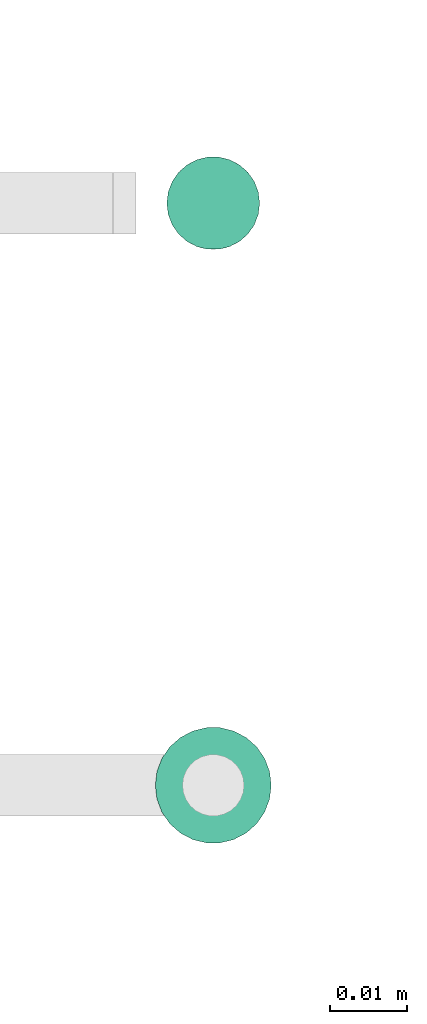
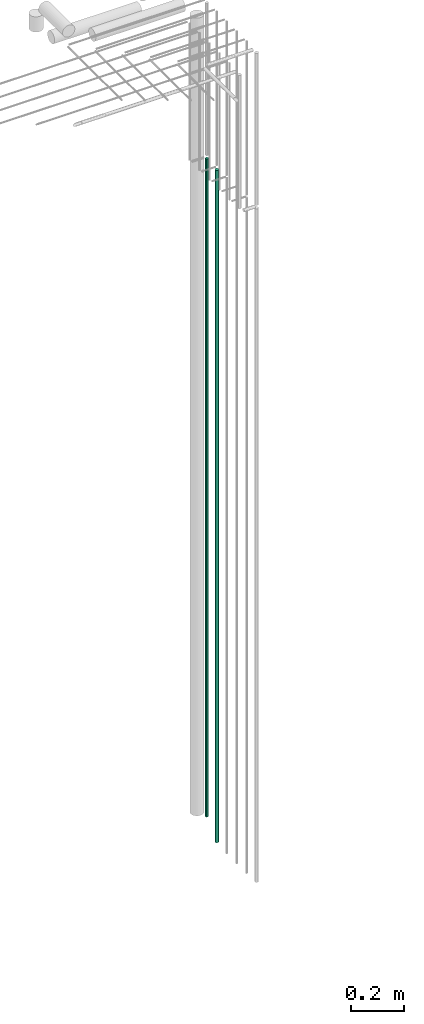
# One storey, part 31 of 89: 2 flow segments.
"""IFC2X3 building model written with IfcOpenShell, lengths in millimetres."""

from ifc_helpers import new_model, entity, si_unit, converted_unit, derived_unit, direction, frame, origin, origin_2d_with_axis, place, context, subcontext, project, spatial, circle, extrude, type_object, element, save


model = new_model("IFC2X3")

# Units and contexts
model_context = context("Model", 3, precision=0.01, world=origin(), true_north=direction((6.12303176911189e-17, 1.0)))
body_context = subcontext(model_context, "Body", "Model", "MODEL_VIEW")
ifc_project = project(units=[si_unit("LENGTHUNIT", "METRE", prefix="MILLI"), si_unit("AREAUNIT", "SQUARE_METRE"), si_unit("VOLUMEUNIT", "CUBIC_METRE"), converted_unit("PLANEANGLEUNIT", "DEGREE", entity("IfcRatioMeasure", 0.0174532925199433), si_unit("PLANEANGLEUNIT", "RADIAN"), dimensions=[0, 0, 0, 0, 0, 0, 0]), si_unit("MASSUNIT", "GRAM", prefix="KILO"), derived_unit("MASSDENSITYUNIT", [(si_unit("MASSUNIT", "GRAM", prefix="KILO"), 1), (si_unit("LENGTHUNIT", "METRE"), -3)]), derived_unit("MOMENTOFINERTIAUNIT", [(si_unit("LENGTHUNIT", "METRE"), 4)]), si_unit("TIMEUNIT", "SECOND"), si_unit("FREQUENCYUNIT", "HERTZ"), si_unit("THERMODYNAMICTEMPERATUREUNIT", "DEGREE_CELSIUS"), derived_unit("THERMALTRANSMITTANCEUNIT", [(si_unit("MASSUNIT", "GRAM", prefix="KILO"), 1), (si_unit("THERMODYNAMICTEMPERATUREUNIT", "KELVIN"), -1), (si_unit("TIMEUNIT", "SECOND"), -3)]), derived_unit("VOLUMETRICFLOWRATEUNIT", [(si_unit("LENGTHUNIT", "METRE"), 3), (si_unit("TIMEUNIT", "SECOND"), -1)]), derived_unit("MASSFLOWRATEUNIT", [(si_unit("MASSUNIT", "GRAM", prefix="KILO"), 1), (si_unit("TIMEUNIT", "SECOND"), -1)]), derived_unit("ROTATIONALFREQUENCYUNIT", [(si_unit("TIMEUNIT", "SECOND"), -1)]), si_unit("ELECTRICCURRENTUNIT", "AMPERE"), si_unit("ELECTRICVOLTAGEUNIT", "VOLT"), si_unit("POWERUNIT", "WATT"), si_unit("FORCEUNIT", "NEWTON", prefix="KILO"), si_unit("ILLUMINANCEUNIT", "LUX"), si_unit("LUMINOUSFLUXUNIT", "LUMEN"), si_unit("LUMINOUSINTENSITYUNIT", "CANDELA"), derived_unit("USERDEFINED", [(si_unit("MASSUNIT", "GRAM", prefix="KILO"), -1), (si_unit("LENGTHUNIT", "METRE"), -2), (si_unit("TIMEUNIT", "SECOND"), 3), (si_unit("LUMINOUSFLUXUNIT", "LUMEN"), 1)]), derived_unit("LINEARVELOCITYUNIT", [(si_unit("LENGTHUNIT", "METRE"), 1), (si_unit("TIMEUNIT", "SECOND"), -1)]), si_unit("PRESSUREUNIT", "PASCAL"), derived_unit("USERDEFINED", [(si_unit("LENGTHUNIT", "METRE"), -2), (si_unit("MASSUNIT", "GRAM", prefix="KILO"), 1), (si_unit("TIMEUNIT", "SECOND"), -2)]), derived_unit("LINEARFORCEUNIT", [(si_unit("MASSUNIT", "GRAM", prefix="KILO"), 1), (si_unit("LENGTHUNIT", "METRE"), 1), (si_unit("TIMEUNIT", "SECOND"), -2), (si_unit("LENGTHUNIT", "METRE"), -1)]), derived_unit("PLANARFORCEUNIT", [(si_unit("MASSUNIT", "GRAM", prefix="KILO"), 1), (si_unit("LENGTHUNIT", "METRE"), 1), (si_unit("TIMEUNIT", "SECOND"), -2), (si_unit("LENGTHUNIT", "METRE"), -2)])], contexts=[model_context])

# Site, building, storey
site_placement = place(None, frame((0.0, -0.00077364408347762, 0.0)))
site = spatial("IfcSite", under=ifc_project, at=site_placement, CompositionType="ELEMENT")
building_placement = place(site_placement, origin())
building = spatial("IfcBuilding", under=site, at=building_placement, CompositionType="ELEMENT")
storey_placement = place(building_placement, frame((0.0, 0.0, 24000.0)))
storey = spatial("IfcBuildingStorey", under=building, at=storey_placement, CompositionType="ELEMENT", Elevation=24000.0)

# Flow segments
pipe_segment_type = type_object("IfcPipeSegmentType", PredefinedType="NOTDEFINED")
flow_segment_1_placement = place(storey_placement, frame((73299.1022607087, 10727.5815154137, -1061.0)))
element("IfcFlowSegment", 1, at=flow_segment_1_placement, inside=storey, type_object=pipe_segment_type, context=body_context, shape_type="SweptSolid", body=[
    extrude(circle(Radius=6.0, at=origin_2d_with_axis()), frame((7.59527223591454, 7.5952722359167, 0.0)), (0.0, 0.0, 1.0), 3029.00000000002),
])
flow_segment_2_placement = place(storey_placement, frame((73297.6022607087, 10650.7784588154, -1132.0)))
element("IfcFlowSegment", 2, at=flow_segment_2_placement, inside=storey, type_object=pipe_segment_type, context=body_context, shape_type="SweptSolid", body=[
    extrude(circle(Radius=7.5, at=origin_2d_with_axis()), frame((9.09527223591419, 9.09527223591636, 0.0)), (0.0, 0.0, 1.0), 3094.00000197254),
])

save(model, "model.ifc")
